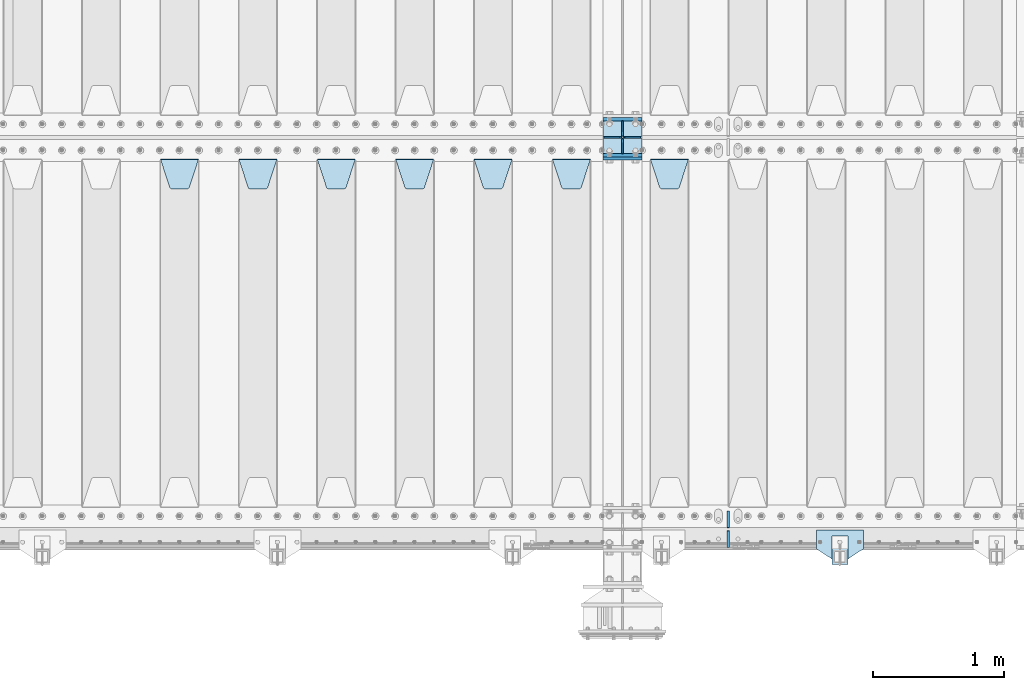
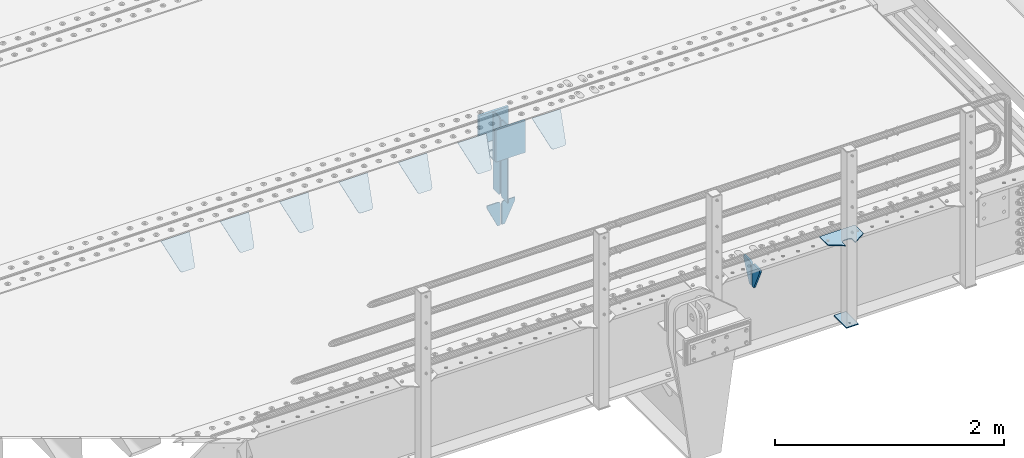
# One storey, part 200 of 240: 22 plates.
"""IFC2X3 building model written with IfcOpenShell, lengths in millimetres."""

from ifc_helpers import new_model, si_unit, frame, origin_with_axes, place, context, subcontext, project, spatial, faceted_brep, material, type_object, element, save


model = new_model("IFC2X3")

# Units and contexts
model_context = context("Model", 3, precision=1e-05, world=origin_with_axes())
body_context = subcontext(model_context, "Body", "Model", "MODEL_VIEW")
ifc_project = project(units=[si_unit("LENGTHUNIT", "METRE", prefix="MILLI"), si_unit("AREAUNIT", "SQUARE_METRE"), si_unit("VOLUMEUNIT", "CUBIC_METRE"), si_unit("MASSUNIT", "GRAM", prefix="KILO"), si_unit("TIMEUNIT", "SECOND"), si_unit("PLANEANGLEUNIT", "RADIAN"), si_unit("SOLIDANGLEUNIT", "STERADIAN"), si_unit("THERMODYNAMICTEMPERATUREUNIT", "DEGREE_CELSIUS"), si_unit("LUMINOUSINTENSITYUNIT", "LUMEN")], contexts=[model_context])

# Site, building, storey
site_placement = place(None, origin_with_axes())
site = spatial("IfcSite", under=ifc_project, at=site_placement, CompositionType="ELEMENT")
building_placement = place(site_placement, origin_with_axes())
building = spatial("IfcBuilding", under=site, at=building_placement, Name="Standard", CompositionType="ELEMENT")
storey_placement = place(building_placement, origin_with_axes())
storey = spatial("IfcBuildingStorey", under=building, at=storey_placement, Name="Undefined", CompositionType="ELEMENT", Elevation=0.0)

# Plates
ifc_material_1 = material(Name="STEEL/S355N")
plate_type_1 = type_object("IfcPlateType", PredefinedType="NOTDEFINED")
for number, where, z_axis, x_axis in (
    (1, (52690.0, 27137.5, -340.0), (0.0, 0.0, 1.0), (1.0, 0.0, 0.0)),
    (2, (52690.0, 26862.5, -340.0), (0.0, 0.0, 1.0), (1.0, 0.0, 0.0)),
):
    element("IfcPlate", number, at=place(storey_placement, frame(where, z_axis=z_axis, x_axis=x_axis)), inside=storey, type_object=plate_type_1, material=ifc_material_1, context=body_context, shape_type="Brep", body=[
        faceted_brep([(0.0, -12.5, 0.0), (0.0, -12.5, 310.0), (0.0, 12.5, 310.0), (0.0, 12.5, 0.0), (300.0, -12.5, 310.0), (300.0, 12.5, 310.0), (300.0, -12.5, 0.0), (300.0, 12.5, 0.0)], [[[0, 1, 2, 3]], [[1, 4, 5, 2]], [[4, 6, 7, 5]], [[6, 0, 3, 7]], [[5, 7, 3, 2]], [[6, 4, 1, 0]]]),
    ])
plate_1_placement = place(storey_placement, frame((52690.0, 26837.5, -340.000000000044), z_axis=(0.0, 0.0, 1.0), x_axis=(1.0, 0.0, 0.0)))
element("IfcPlate", 3, at=plate_1_placement, inside=storey, type_object=plate_type_1, material=ifc_material_1, context=body_context, shape_type="Brep", body=[
    faceted_brep([(0.0, -12.5, 0.0), (9.31322574615479e-10, -12.5, 340.0), (9.31322574615479e-10, 12.5, 340.0), (0.0, 12.5, 0.0), (300.0, -12.5, 340.0), (300.0, 12.5, 340.0), (300.0, -12.5, 0.0), (300.0, 12.5, 0.0)], [[[0, 1, 2, 3]], [[1, 4, 5, 2]], [[4, 6, 7, 5]], [[6, 0, 3, 7]], [[5, 7, 3, 2]], [[6, 4, 1, 0]]]),
])
plate_type_2 = type_object("IfcPlateType", PredefinedType="NOTDEFINED")
for number, where, z_axis, x_axis in (
    (4, (52690.0, 26992.0, -343.0), (0.0, -1.0, 0.0), (1.0, 0.0, 0.0)),
    (5, (52690.0, 27008.0, -343.0), (0.0, 1.0, 0.0), (1.0, 0.0, 0.0)),
):
    element("IfcPlate", number, at=place(storey_placement, frame(where, z_axis=z_axis, x_axis=x_axis)), inside=storey, type_object=plate_type_2, material=ifc_material_1, context=body_context, shape_type="Brep", body=[
        faceted_brep([(0.0, -7.0, 0.0), (0.0, -7.0, 117.0), (0.0, 7.0, 117.0), (0.0, 7.0, 0.0), (300.0, -7.0, 117.0), (300.0, 7.0, 117.0), (300.0, -7.0, 0.0), (300.0, 7.0, 0.0)], [[[0, 1, 2, 3]], [[1, 4, 5, 2]], [[4, 6, 7, 5]], [[6, 0, 3, 7]], [[5, 7, 3, 2]], [[6, 4, 1, 0]]]),
    ])
plate_type_3 = type_object("IfcPlateType", PredefinedType="NOTDEFINED")
for number, where, z_axis, x_axis in (
    (6, (52840.0, 27008.0, -30.0), (0.0, 0.0, -1.0), (0.0, 1.0, 0.0)),
    (7, (52840.0, 26992.0, -30.0), (0.0, 0.0, -1.0), (0.0, -1.0, 0.0)),
):
    element("IfcPlate", number, at=place(storey_placement, frame(where, z_axis=z_axis, x_axis=x_axis)), inside=storey, type_object=plate_type_3, material=ifc_material_1, context=body_context, shape_type="Brep", body=[
        faceted_brep([(0.0, -5.0, 30.0), (0.0, -5.0, 306.0), (0.0, 5.0, 306.0), (0.0, 5.0, 30.0), (117.0, -5.0, 306.0), (117.0, 5.0, 306.0), (117.0, -5.0, 0.0), (117.0, 5.0, 0.0), (30.0, -5.0, 0.0), (30.0, 5.0, 0.0), (24.7905546699913, -5.0, 0.455767409633758), (24.7905546699913, 5.0, 0.455767409633758), (19.7393957002278, -5.0, 1.80922137642275), (19.7393957002278, 5.0, 1.80922137642275), (15.0, -5.0, 4.01923788646684), (15.0, 5.0, 4.01923788646684), (10.7163717094008, -5.0, 7.01866670643066), (10.7163717094008, 5.0, 7.01866670643066), (7.01866670643358, -5.0, 10.7163717094038), (7.01866670643358, 5.0, 10.7163717094038), (4.01923788646673, -5.0, 15.0), (4.01923788646673, 5.0, 15.0), (1.80922137642483, -5.0, 19.7393957002299), (1.80922137642483, 5.0, 19.7393957002299), (0.455767409635882, -5.0, 24.7905546699921), (0.455767409635882, 5.0, 24.7905546699921)], [[[0, 1, 2, 3]], [[1, 4, 5, 2]], [[4, 6, 7, 5]], [[6, 8, 9, 7]], [[8, 10, 11, 9]], [[10, 12, 13, 11]], [[12, 14, 15, 13]], [[14, 16, 17, 15]], [[16, 18, 19, 17]], [[18, 20, 21, 19]], [[20, 22, 23, 21]], [[22, 24, 25, 23]], [[24, 0, 3, 25]], [[5, 7, 9, 11, 13, 15, 17, 19, 21, 23, 25, 3, 2]], [[24, 22, 20, 18, 16, 14, 12, 10, 8, 6, 4, 1, 0]]]),
    ])
for number, where, z_axis, x_axis in (
    (8, (52840.0, 26992.0, -350.0), (0.0, 0.0, -1.0), (0.0, -1.0, 0.0)),
    (9, (52840.0, 27008.0, -350.0), (0.0, 0.0, -1.0), (0.0, 1.0, 0.0)),
):
    element("IfcPlate", number, at=place(storey_placement, frame(where, z_axis=z_axis, x_axis=x_axis)), inside=storey, type_object=plate_type_3, material=ifc_material_1, context=body_context, shape_type="Brep", body=[
        faceted_brep([(0.0, -5.0, 0.0), (0.0, -5.0, 480.0), (0.0, 5.0, 480.0), (0.0, 5.0, 0.0), (0.455767409635882, -5.0, 485.209445330008), (0.455767409635882, 5.0, 485.209445330008), (1.80922137642483, -5.0, 490.26060429977), (1.80922137642483, 5.0, 490.26060429977), (4.01923788646673, -5.0, 495.0), (4.01923788646673, 5.0, 495.0), (7.01866670643358, -5.0, 499.283628290596), (7.01866670643358, 5.0, 499.283628290596), (10.7163717094008, -5.0, 502.981333293569), (10.7163717094008, 5.0, 502.981333293569), (15.0, -5.0, 505.980762113533), (15.0, 5.0, 505.980762113533), (19.7393957002278, -5.0, 508.190778623577), (19.7393957002278, 5.0, 508.190778623577), (24.7905546699913, -5.0, 509.544232590366), (24.7905546699913, 5.0, 509.544232590366), (30.0, -5.0, 510.0), (30.0, 5.0, 510.0), (117.0, -5.0, 510.0), (117.0, 5.0, 510.0), (117.0, -5.0, 0.0), (117.0, 5.0, 0.0)], [[[0, 1, 2, 3]], [[1, 4, 5, 2]], [[4, 6, 7, 5]], [[6, 8, 9, 7]], [[8, 10, 11, 9]], [[10, 12, 13, 11]], [[12, 14, 15, 13]], [[14, 16, 17, 15]], [[16, 18, 19, 17]], [[18, 20, 21, 19]], [[20, 22, 23, 21]], [[22, 24, 25, 23]], [[24, 0, 3, 25]], [[5, 7, 9, 11, 13, 15, 17, 19, 21, 23, 25, 3, 2]], [[24, 22, 20, 18, 16, 14, 12, 10, 8, 6, 4, 1, 0]]]),
    ])
plate_type_4 = type_object("IfcPlateType", PredefinedType="NOTDEFINED")
for number, where, z_axis, x_axis in (
    (10, (52833.4999999989, 27000.0000000345, -915.000018222274), (0.0, 0.0, -1.0), (-1.0, 0.0, 0.0)),
    (11, (52846.4999999991, 27000.0000000345, -915.000018222273), (0.0, 0.0, -1.0), (1.0, 0.0, 0.0)),
):
    element("IfcPlate", number, at=place(storey_placement, frame(where, z_axis=z_axis, x_axis=x_axis)), inside=storey, type_object=plate_type_4, material=ifc_material_1, context=body_context, shape_type="Brep", body=[
        faceted_brep([(0.0, -5.0, 27.0), (0.0, -5.0, 250.0), (0.0, 5.0, 250.0), (0.0, 5.0, 27.0), (30.0, -5.0, 250.0), (30.0, 5.0, 250.0), (135.0, -5.0, 30.0), (135.0, 5.0, 30.0), (135.0, -5.0, 0.0), (135.0, 5.0, 0.0), (27.0, -5.0, 0.0), (27.0, 5.0, 0.0), (22.311499202995, -5.0, 0.410190668670339), (22.311499202995, 5.0, 0.410190668670339), (17.7654561302043, -5.0, 1.62829923878053), (17.7654561302043, 5.0, 1.62829923878053), (13.5, -5.0, 3.6173140978201), (13.5, 5.0, 3.6173140978201), (9.64473453846585, -5.0, 6.31680003578754), (9.64473453846585, 5.0, 6.31680003578754), (6.31680003579095, -5.0, 9.64473453846347), (6.31680003579095, 5.0, 9.64473453846347), (3.61731409782078, -5.0, 13.5), (3.61731409782078, 5.0, 13.5), (1.62829923877871, -5.0, 17.765456130207), (1.62829923877871, 5.0, 17.765456130207), (0.410190668670111, -5.0, 22.3114992029929), (0.410190668670111, 5.0, 22.3114992029929)], [[[0, 1, 2, 3]], [[1, 4, 5, 2]], [[4, 6, 7, 5]], [[6, 8, 9, 7]], [[8, 10, 11, 9]], [[10, 12, 13, 11]], [[12, 14, 15, 13]], [[14, 16, 17, 15]], [[16, 18, 19, 17]], [[18, 20, 21, 19]], [[20, 22, 23, 21]], [[22, 24, 25, 23]], [[24, 26, 27, 25]], [[26, 0, 3, 27]], [[5, 7, 9, 11, 13, 15, 17, 19, 21, 23, 25, 27, 3, 2]], [[26, 24, 22, 20, 18, 16, 14, 12, 10, 8, 6, 4, 1, 0]]]),
    ])
plate_type_5 = type_object("IfcPlateType", PredefinedType="NOTDEFINED")
plate_2_placement = place(storey_placement, frame((53055.0, 26831.767766956, -1.76776695296758), z_axis=(0.0, -0.707106781186547, -0.707106781186548), x_axis=(1.0, 0.0, 0.0)))
element("IfcPlate", 12, at=plate_2_placement, inside=storey, type_object=plate_type_5, material=ifc_material_1, context=body_context, shape_type="Brep", body=[
    faceted_brep([(0.0, -2.5, 0.0), (69.345504679477, -2.50000000000364, 300.171731424827), (69.345504679477, 2.49999999999636, 300.171731424827), (0.0, 2.5, 0.0), (70.927406119954, -2.50000000000364, 304.897442415397), (70.927406119954, 2.49999999999636, 304.897442415397), (73.3818627772271, -2.50000000000728, 309.234538108525), (73.3818627772271, 2.49999999999636, 309.234538108529), (76.6187032999587, -2.50000000000728, 313.023683126099), (76.6187032999587, 2.49999999999636, 313.023683126103), (80.5190132705029, -2.50000000000364, 316.125672595368), (80.5190132705029, 2.49999999999636, 316.125672595368), (84.9395038596849, -2.50000000000364, 318.426546230472), (84.9395038596849, 2.49999999999636, 318.426546230472), (89.7177759439219, -2.5, 319.841774983277), (89.7177759439219, 2.49999999999636, 319.841774983273), (94.6782862926484, -2.50000000000364, 320.319366455074), (94.6782862926484, 2.49999999999636, 320.319366455074), (195.321713707352, -2.50000000000364, 320.319366455074), (195.321713707352, 2.49999999999636, 320.319366455074), (200.282224056078, -2.50000000000364, 319.841774983273), (200.282224056078, 2.49999999999636, 319.841774983273), (205.060496140315, -2.50000000000364, 318.426546230472), (205.060496140315, 2.49999999999636, 318.426546230472), (209.480986729497, -2.50000000000364, 316.125672595368), (209.480986729497, 2.49999999999636, 316.125672595368), (213.381296700041, -2.50000000000728, 313.023683126099), (213.381296700041, 2.49999999999272, 313.023683126099), (216.618137222766, -2.50000000000364, 309.234538108522), (216.618137222766, 2.49999999999636, 309.234538108522), (219.072593880039, -2.50000000000364, 304.897442415397), (219.072593880039, 2.49999999999636, 304.897442415397), (220.654495320523, -2.50000000000364, 300.171731424827), (220.654495320523, 2.49999999999636, 300.171731424827), (290.0, -2.50000000000364, -3.63797880709171e-12), (290.0, 2.49999999999636, -3.63797880709171e-12)], [[[0, 1, 2, 3]], [[1, 4, 5, 2]], [[4, 6, 7, 5]], [[6, 8, 9, 7]], [[8, 10, 11, 9]], [[10, 12, 13, 11]], [[12, 14, 15, 13]], [[14, 16, 17, 15]], [[16, 18, 19, 17]], [[18, 20, 21, 19]], [[20, 22, 23, 21]], [[22, 24, 25, 23]], [[24, 26, 27, 25]], [[26, 28, 29, 27]], [[28, 30, 31, 29]], [[30, 32, 33, 31]], [[32, 34, 35, 33]], [[34, 0, 3, 35]], [[5, 7, 9, 11, 13, 15, 17, 19, 21, 23, 25, 27, 29, 31, 33, 35, 3, 2]], [[34, 32, 30, 28, 26, 24, 22, 20, 18, 16, 14, 12, 10, 8, 6, 4, 1, 0]]]),
])
plate_3_placement = place(storey_placement, frame((52305.0, 26831.767766956, -1.76776695296758), z_axis=(0.0, -0.707106781186547, -0.707106781186548), x_axis=(1.0, 0.0, 0.0)))
element("IfcPlate", 13, at=plate_3_placement, inside=storey, type_object=plate_type_5, material=ifc_material_1, context=body_context, shape_type="Brep", body=[
    faceted_brep([(0.0, -2.5, 0.0), (69.345504679477, -2.50000000000364, 300.171731424827), (69.345504679477, 2.49999999999636, 300.171731424827), (0.0, 2.5, 0.0), (70.927406119954, -2.50000000000364, 304.897442415397), (70.927406119954, 2.49999999999636, 304.897442415397), (73.3818627772271, -2.50000000000728, 309.234538108525), (73.3818627772271, 2.49999999999636, 309.234538108529), (76.6187032999587, -2.50000000000728, 313.023683126099), (76.6187032999587, 2.49999999999636, 313.023683126103), (80.5190132705029, -2.50000000000364, 316.125672595368), (80.5190132705029, 2.49999999999636, 316.125672595368), (84.9395038596849, -2.50000000000364, 318.426546230472), (84.9395038596849, 2.49999999999636, 318.426546230472), (89.7177759439219, -2.5, 319.841774983277), (89.7177759439219, 2.49999999999636, 319.841774983273), (94.6782862926484, -2.50000000000364, 320.319366455074), (94.6782862926484, 2.49999999999636, 320.319366455074), (195.321713707352, -2.50000000000364, 320.319366455074), (195.321713707352, 2.49999999999636, 320.319366455074), (200.282224056078, -2.50000000000364, 319.841774983273), (200.282224056078, 2.49999999999636, 319.841774983273), (205.060496140315, -2.50000000000364, 318.426546230472), (205.060496140315, 2.49999999999636, 318.426546230472), (209.480986729497, -2.50000000000364, 316.125672595368), (209.480986729497, 2.49999999999636, 316.125672595368), (213.381296700041, -2.50000000000728, 313.023683126099), (213.381296700041, 2.49999999999272, 313.023683126099), (216.618137222766, -2.50000000000364, 309.234538108522), (216.618137222766, 2.49999999999636, 309.234538108522), (219.072593880039, -2.50000000000364, 304.897442415397), (219.072593880039, 2.49999999999636, 304.897442415397), (220.654495320523, -2.50000000000364, 300.171731424827), (220.654495320523, 2.49999999999636, 300.171731424827), (290.0, -2.50000000000364, -3.63797880709171e-12), (290.0, 2.49999999999636, -3.63797880709171e-12)], [[[0, 1, 2, 3]], [[1, 4, 5, 2]], [[4, 6, 7, 5]], [[6, 8, 9, 7]], [[8, 10, 11, 9]], [[10, 12, 13, 11]], [[12, 14, 15, 13]], [[14, 16, 17, 15]], [[16, 18, 19, 17]], [[18, 20, 21, 19]], [[20, 22, 23, 21]], [[22, 24, 25, 23]], [[24, 26, 27, 25]], [[26, 28, 29, 27]], [[28, 30, 31, 29]], [[30, 32, 33, 31]], [[32, 34, 35, 33]], [[34, 0, 3, 35]], [[5, 7, 9, 11, 13, 15, 17, 19, 21, 23, 25, 27, 29, 31, 33, 35, 3, 2]], [[34, 32, 30, 28, 26, 24, 22, 20, 18, 16, 14, 12, 10, 8, 6, 4, 1, 0]]]),
])
plate_4_placement = place(storey_placement, frame((51705.0, 26831.767766956, -1.76776695296758), z_axis=(0.0, -0.707106781186547, -0.707106781186548), x_axis=(1.0, 0.0, 0.0)))
element("IfcPlate", 14, at=plate_4_placement, inside=storey, type_object=plate_type_5, material=ifc_material_1, context=body_context, shape_type="Brep", body=[
    faceted_brep([(0.0, -2.5, 0.0), (69.345504679477, -2.50000000000364, 300.171731424827), (69.345504679477, 2.49999999999636, 300.171731424827), (0.0, 2.5, 0.0), (70.927406119954, -2.50000000000364, 304.897442415397), (70.927406119954, 2.49999999999636, 304.897442415397), (73.3818627772271, -2.50000000000728, 309.234538108525), (73.3818627772271, 2.49999999999636, 309.234538108529), (76.6187032999587, -2.50000000000728, 313.023683126099), (76.6187032999587, 2.49999999999636, 313.023683126103), (80.5190132705029, -2.50000000000364, 316.125672595368), (80.5190132705029, 2.49999999999636, 316.125672595368), (84.9395038596849, -2.50000000000364, 318.426546230472), (84.9395038596849, 2.49999999999636, 318.426546230472), (89.7177759439219, -2.5, 319.841774983277), (89.7177759439219, 2.49999999999636, 319.841774983273), (94.6782862926484, -2.50000000000364, 320.319366455074), (94.6782862926484, 2.49999999999636, 320.319366455074), (195.321713707352, -2.50000000000364, 320.319366455074), (195.321713707352, 2.49999999999636, 320.319366455074), (200.282224056078, -2.50000000000364, 319.841774983273), (200.282224056078, 2.49999999999636, 319.841774983273), (205.060496140315, -2.50000000000364, 318.426546230472), (205.060496140315, 2.49999999999636, 318.426546230472), (209.480986729497, -2.50000000000364, 316.125672595368), (209.480986729497, 2.49999999999636, 316.125672595368), (213.381296700041, -2.50000000000728, 313.023683126099), (213.381296700041, 2.49999999999272, 313.023683126099), (216.618137222766, -2.50000000000364, 309.234538108522), (216.618137222766, 2.49999999999636, 309.234538108522), (219.072593880039, -2.50000000000364, 304.897442415397), (219.072593880039, 2.49999999999636, 304.897442415397), (220.654495320523, -2.50000000000364, 300.171731424827), (220.654495320523, 2.49999999999636, 300.171731424827), (290.0, -2.50000000000364, -3.63797880709171e-12), (290.0, 2.49999999999636, -3.63797880709171e-12)], [[[0, 1, 2, 3]], [[1, 4, 5, 2]], [[4, 6, 7, 5]], [[6, 8, 9, 7]], [[8, 10, 11, 9]], [[10, 12, 13, 11]], [[12, 14, 15, 13]], [[14, 16, 17, 15]], [[16, 18, 19, 17]], [[18, 20, 21, 19]], [[20, 22, 23, 21]], [[22, 24, 25, 23]], [[24, 26, 27, 25]], [[26, 28, 29, 27]], [[28, 30, 31, 29]], [[30, 32, 33, 31]], [[32, 34, 35, 33]], [[34, 0, 3, 35]], [[5, 7, 9, 11, 13, 15, 17, 19, 21, 23, 25, 27, 29, 31, 33, 35, 3, 2]], [[34, 32, 30, 28, 26, 24, 22, 20, 18, 16, 14, 12, 10, 8, 6, 4, 1, 0]]]),
])
plate_5_placement = place(storey_placement, frame((51105.0, 26831.767766956, -1.76776695296758), z_axis=(0.0, -0.707106781186547, -0.707106781186548), x_axis=(1.0, 0.0, 0.0)))
element("IfcPlate", 15, at=plate_5_placement, inside=storey, type_object=plate_type_5, material=ifc_material_1, context=body_context, shape_type="Brep", body=[
    faceted_brep([(0.0, -2.5, 0.0), (69.345504679477, -2.50000000000364, 300.171731424827), (69.345504679477, 2.49999999999636, 300.171731424827), (0.0, 2.5, 0.0), (70.927406119954, -2.50000000000364, 304.897442415397), (70.927406119954, 2.49999999999636, 304.897442415397), (73.3818627772271, -2.50000000000728, 309.234538108525), (73.3818627772271, 2.49999999999636, 309.234538108529), (76.6187032999587, -2.50000000000728, 313.023683126099), (76.6187032999587, 2.49999999999636, 313.023683126103), (80.5190132705029, -2.50000000000364, 316.125672595368), (80.5190132705029, 2.49999999999636, 316.125672595368), (84.9395038596849, -2.50000000000364, 318.426546230472), (84.9395038596849, 2.49999999999636, 318.426546230472), (89.7177759439219, -2.5, 319.841774983277), (89.7177759439219, 2.49999999999636, 319.841774983273), (94.6782862926484, -2.50000000000364, 320.319366455074), (94.6782862926484, 2.49999999999636, 320.319366455074), (195.321713707352, -2.50000000000364, 320.319366455074), (195.321713707352, 2.49999999999636, 320.319366455074), (200.282224056078, -2.50000000000364, 319.841774983273), (200.282224056078, 2.49999999999636, 319.841774983273), (205.060496140315, -2.50000000000364, 318.426546230472), (205.060496140315, 2.49999999999636, 318.426546230472), (209.480986729497, -2.50000000000364, 316.125672595368), (209.480986729497, 2.49999999999636, 316.125672595368), (213.381296700041, -2.50000000000728, 313.023683126099), (213.381296700041, 2.49999999999272, 313.023683126099), (216.618137222766, -2.50000000000364, 309.234538108522), (216.618137222766, 2.49999999999636, 309.234538108522), (219.072593880039, -2.50000000000364, 304.897442415397), (219.072593880039, 2.49999999999636, 304.897442415397), (220.654495320523, -2.50000000000364, 300.171731424827), (220.654495320523, 2.49999999999636, 300.171731424827), (290.0, -2.50000000000364, -3.63797880709171e-12), (290.0, 2.49999999999636, -3.63797880709171e-12)], [[[0, 1, 2, 3]], [[1, 4, 5, 2]], [[4, 6, 7, 5]], [[6, 8, 9, 7]], [[8, 10, 11, 9]], [[10, 12, 13, 11]], [[12, 14, 15, 13]], [[14, 16, 17, 15]], [[16, 18, 19, 17]], [[18, 20, 21, 19]], [[20, 22, 23, 21]], [[22, 24, 25, 23]], [[24, 26, 27, 25]], [[26, 28, 29, 27]], [[28, 30, 31, 29]], [[30, 32, 33, 31]], [[32, 34, 35, 33]], [[34, 0, 3, 35]], [[5, 7, 9, 11, 13, 15, 17, 19, 21, 23, 25, 27, 29, 31, 33, 35, 3, 2]], [[34, 32, 30, 28, 26, 24, 22, 20, 18, 16, 14, 12, 10, 8, 6, 4, 1, 0]]]),
])
plate_6_placement = place(storey_placement, frame((50505.0, 26831.767766956, -1.76776695296758), z_axis=(0.0, -0.707106781186547, -0.707106781186548), x_axis=(1.0, 0.0, 0.0)))
element("IfcPlate", 16, at=plate_6_placement, inside=storey, type_object=plate_type_5, material=ifc_material_1, context=body_context, shape_type="Brep", body=[
    faceted_brep([(0.0, -2.5, 0.0), (69.345504679477, -2.50000000000364, 300.171731424827), (69.345504679477, 2.49999999999636, 300.171731424827), (0.0, 2.5, 0.0), (70.927406119954, -2.50000000000364, 304.897442415397), (70.927406119954, 2.49999999999636, 304.897442415397), (73.3818627772271, -2.50000000000728, 309.234538108525), (73.3818627772271, 2.49999999999636, 309.234538108529), (76.6187032999587, -2.50000000000728, 313.023683126099), (76.6187032999587, 2.49999999999636, 313.023683126103), (80.5190132705029, -2.50000000000364, 316.125672595368), (80.5190132705029, 2.49999999999636, 316.125672595368), (84.9395038596849, -2.50000000000364, 318.426546230472), (84.9395038596849, 2.49999999999636, 318.426546230472), (89.7177759439219, -2.5, 319.841774983277), (89.7177759439219, 2.49999999999636, 319.841774983273), (94.6782862926484, -2.50000000000364, 320.319366455074), (94.6782862926484, 2.49999999999636, 320.319366455074), (195.321713707352, -2.50000000000364, 320.319366455074), (195.321713707352, 2.49999999999636, 320.319366455074), (200.282224056078, -2.50000000000364, 319.841774983273), (200.282224056078, 2.49999999999636, 319.841774983273), (205.060496140315, -2.50000000000364, 318.426546230472), (205.060496140315, 2.49999999999636, 318.426546230472), (209.480986729497, -2.50000000000364, 316.125672595368), (209.480986729497, 2.49999999999636, 316.125672595368), (213.381296700041, -2.50000000000728, 313.023683126099), (213.381296700041, 2.49999999999272, 313.023683126099), (216.618137222766, -2.50000000000364, 309.234538108522), (216.618137222766, 2.49999999999636, 309.234538108522), (219.072593880039, -2.50000000000364, 304.897442415397), (219.072593880039, 2.49999999999636, 304.897442415397), (220.654495320523, -2.50000000000364, 300.171731424827), (220.654495320523, 2.49999999999636, 300.171731424827), (290.0, -2.50000000000364, -3.63797880709171e-12), (290.0, 2.49999999999636, -3.63797880709171e-12)], [[[0, 1, 2, 3]], [[1, 4, 5, 2]], [[4, 6, 7, 5]], [[6, 8, 9, 7]], [[8, 10, 11, 9]], [[10, 12, 13, 11]], [[12, 14, 15, 13]], [[14, 16, 17, 15]], [[16, 18, 19, 17]], [[18, 20, 21, 19]], [[20, 22, 23, 21]], [[22, 24, 25, 23]], [[24, 26, 27, 25]], [[26, 28, 29, 27]], [[28, 30, 31, 29]], [[30, 32, 33, 31]], [[32, 34, 35, 33]], [[34, 0, 3, 35]], [[5, 7, 9, 11, 13, 15, 17, 19, 21, 23, 25, 27, 29, 31, 33, 35, 3, 2]], [[34, 32, 30, 28, 26, 24, 22, 20, 18, 16, 14, 12, 10, 8, 6, 4, 1, 0]]]),
])
plate_7_placement = place(storey_placement, frame((49905.0, 26831.767766956, -1.76776695296758), z_axis=(0.0, -0.707106781186547, -0.707106781186548), x_axis=(1.0, 0.0, 0.0)))
element("IfcPlate", 17, at=plate_7_placement, inside=storey, type_object=plate_type_5, material=ifc_material_1, context=body_context, shape_type="Brep", body=[
    faceted_brep([(0.0, -2.5, 0.0), (69.345504679477, -2.50000000000364, 300.171731424827), (69.345504679477, 2.49999999999636, 300.171731424827), (0.0, 2.5, 0.0), (70.927406119954, -2.50000000000364, 304.897442415397), (70.927406119954, 2.49999999999636, 304.897442415397), (73.3818627772271, -2.50000000000728, 309.234538108525), (73.3818627772271, 2.49999999999636, 309.234538108529), (76.6187032999587, -2.50000000000728, 313.023683126099), (76.6187032999587, 2.49999999999636, 313.023683126103), (80.5190132705029, -2.50000000000364, 316.125672595368), (80.5190132705029, 2.49999999999636, 316.125672595368), (84.9395038596849, -2.50000000000364, 318.426546230472), (84.9395038596849, 2.49999999999636, 318.426546230472), (89.7177759439219, -2.5, 319.841774983277), (89.7177759439219, 2.49999999999636, 319.841774983273), (94.6782862926484, -2.50000000000364, 320.319366455074), (94.6782862926484, 2.49999999999636, 320.319366455074), (195.321713707352, -2.50000000000364, 320.319366455074), (195.321713707352, 2.49999999999636, 320.319366455074), (200.282224056078, -2.50000000000364, 319.841774983273), (200.282224056078, 2.49999999999636, 319.841774983273), (205.060496140315, -2.50000000000364, 318.426546230472), (205.060496140315, 2.49999999999636, 318.426546230472), (209.480986729497, -2.50000000000364, 316.125672595368), (209.480986729497, 2.49999999999636, 316.125672595368), (213.381296700041, -2.50000000000728, 313.023683126099), (213.381296700041, 2.49999999999272, 313.023683126099), (216.618137222766, -2.50000000000364, 309.234538108522), (216.618137222766, 2.49999999999636, 309.234538108522), (219.072593880039, -2.50000000000364, 304.897442415397), (219.072593880039, 2.49999999999636, 304.897442415397), (220.654495320523, -2.50000000000364, 300.171731424827), (220.654495320523, 2.49999999999636, 300.171731424827), (290.0, -2.50000000000364, -3.63797880709171e-12), (290.0, 2.49999999999636, -3.63797880709171e-12)], [[[0, 1, 2, 3]], [[1, 4, 5, 2]], [[4, 6, 7, 5]], [[6, 8, 9, 7]], [[8, 10, 11, 9]], [[10, 12, 13, 11]], [[12, 14, 15, 13]], [[14, 16, 17, 15]], [[16, 18, 19, 17]], [[18, 20, 21, 19]], [[20, 22, 23, 21]], [[22, 24, 25, 23]], [[24, 26, 27, 25]], [[26, 28, 29, 27]], [[28, 30, 31, 29]], [[30, 32, 33, 31]], [[32, 34, 35, 33]], [[34, 0, 3, 35]], [[5, 7, 9, 11, 13, 15, 17, 19, 21, 23, 25, 27, 29, 31, 33, 35, 3, 2]], [[34, 32, 30, 28, 26, 24, 22, 20, 18, 16, 14, 12, 10, 8, 6, 4, 1, 0]]]),
])
plate_8_placement = place(storey_placement, frame((49305.0, 26831.767766956, -1.76776695296758), z_axis=(0.0, -0.707106781186547, -0.707106781186548), x_axis=(1.0, 0.0, 0.0)))
element("IfcPlate", 18, at=plate_8_placement, inside=storey, type_object=plate_type_5, material=ifc_material_1, context=body_context, shape_type="Brep", body=[
    faceted_brep([(0.0, -2.5, 0.0), (69.345504679477, -2.50000000000364, 300.171731424827), (69.345504679477, 2.49999999999636, 300.171731424827), (0.0, 2.5, 0.0), (70.927406119954, -2.50000000000364, 304.897442415397), (70.927406119954, 2.49999999999636, 304.897442415397), (73.3818627772271, -2.50000000000728, 309.234538108525), (73.3818627772271, 2.49999999999636, 309.234538108529), (76.6187032999587, -2.50000000000728, 313.023683126099), (76.6187032999587, 2.49999999999636, 313.023683126103), (80.5190132705029, -2.50000000000364, 316.125672595368), (80.5190132705029, 2.49999999999636, 316.125672595368), (84.9395038596849, -2.50000000000364, 318.426546230472), (84.9395038596849, 2.49999999999636, 318.426546230472), (89.7177759439219, -2.5, 319.841774983277), (89.7177759439219, 2.49999999999636, 319.841774983273), (94.6782862926484, -2.50000000000364, 320.319366455074), (94.6782862926484, 2.49999999999636, 320.319366455074), (195.321713707352, -2.50000000000364, 320.319366455074), (195.321713707352, 2.49999999999636, 320.319366455074), (200.282224056078, -2.50000000000364, 319.841774983273), (200.282224056078, 2.49999999999636, 319.841774983273), (205.060496140315, -2.50000000000364, 318.426546230472), (205.060496140315, 2.49999999999636, 318.426546230472), (209.480986729497, -2.50000000000364, 316.125672595368), (209.480986729497, 2.49999999999636, 316.125672595368), (213.381296700041, -2.50000000000728, 313.023683126099), (213.381296700041, 2.49999999999272, 313.023683126099), (216.618137222766, -2.50000000000364, 309.234538108522), (216.618137222766, 2.49999999999636, 309.234538108522), (219.072593880039, -2.50000000000364, 304.897442415397), (219.072593880039, 2.49999999999636, 304.897442415397), (220.654495320523, -2.50000000000364, 300.171731424827), (220.654495320523, 2.49999999999636, 300.171731424827), (290.0, -2.50000000000364, -3.63797880709171e-12), (290.0, 2.49999999999636, -3.63797880709171e-12)], [[[0, 1, 2, 3]], [[1, 4, 5, 2]], [[4, 6, 7, 5]], [[6, 8, 9, 7]], [[8, 10, 11, 9]], [[10, 12, 13, 11]], [[12, 14, 15, 13]], [[14, 16, 17, 15]], [[16, 18, 19, 17]], [[18, 20, 21, 19]], [[20, 22, 23, 21]], [[22, 24, 25, 23]], [[24, 26, 27, 25]], [[26, 28, 29, 27]], [[28, 30, 31, 29]], [[30, 32, 33, 31]], [[32, 34, 35, 33]], [[34, 0, 3, 35]], [[5, 7, 9, 11, 13, 15, 17, 19, 21, 23, 25, 27, 29, 31, 33, 35, 3, 2]], [[34, 32, 30, 28, 26, 24, 22, 20, 18, 16, 14, 12, 10, 8, 6, 4, 1, 0]]]),
])
plate_type_6 = type_object("IfcPlateType", PredefinedType="NOTDEFINED")
for number, where, z_axis, x_axis in (
    (19, (53650.0, 23860.0, -30.0), (0.0, 0.0, -1.0), (0.0, 1.0, 0.0)),
    (20, (53650.0, 24140.0, -30.0), (0.0, 0.0, -1.0), (0.0, -1.0, 0.0)),
):
    element("IfcPlate", number, at=place(storey_placement, frame(where, z_axis=z_axis, x_axis=x_axis)), inside=storey, type_object=plate_type_6, material=ifc_material_1, context=body_context, shape_type="Brep", body=[
        faceted_brep([(0.0, -10.0, 0.0), (0.0, -10.0, 30.0), (0.0, 10.0, 30.0), (0.0, 10.0, 0.0), (102.0, -10.0, 250.0), (102.0, 10.0, 250.0), (132.0, -10.0, 250.0), (132.0, 10.0, 250.0), (132.0, -10.0, 30.0), (132.0, 10.0, 30.0), (131.544232590368, -10.0, 24.790554669992), (131.544232590368, 10.0, 24.790554669992), (130.190778623579, -10.0, 19.7393957002299), (130.190778623579, 10.0, 19.7393957002299), (127.980762113533, -10.0, 15.0), (127.980762113533, 10.0, 15.0), (124.98133329357, -10.0, 10.7163717094038), (124.98133329357, 10.0, 10.7163717094038), (121.283628290596, -10.0, 7.01866670643062), (121.283628290596, 10.0, 7.01866670643062), (117.0, -10.0, 4.01923788646684), (117.0, 10.0, 4.01923788646684), (112.260604299769, -10.0, 1.80922137642278), (112.260604299769, 10.0, 1.80922137642278), (107.209445330009, -10.0, 0.455767409633722), (107.209445330009, 10.0, 0.455767409633722), (102.0, -10.0, 0.0), (102.0, 10.0, 0.0)], [[[0, 1, 2, 3]], [[1, 4, 5, 2]], [[4, 6, 7, 5]], [[6, 8, 9, 7]], [[8, 10, 11, 9]], [[10, 12, 13, 11]], [[12, 14, 15, 13]], [[14, 16, 17, 15]], [[16, 18, 19, 17]], [[18, 20, 21, 19]], [[20, 22, 23, 21]], [[22, 24, 25, 23]], [[24, 26, 27, 25]], [[26, 0, 3, 27]], [[5, 7, 9, 11, 13, 15, 17, 19, 21, 23, 25, 27, 3, 2]], [[26, 24, 22, 20, 18, 16, 14, 12, 10, 8, 6, 4, 1, 0]]]),
    ])
ifc_material_2 = material(Name="STEEL/S355J2")
plate_type_7 = type_object("IfcPlateType", PredefinedType="NOTDEFINED")
plate_9_placement = place(storey_placement, frame((54685.0, 23995.0, 5.00000000004911), z_axis=(0.0, -1.0, 0.0), x_axis=(-1.0, 0.0, 0.0)))
element("IfcPlate", 21, at=plate_9_placement, inside=storey, type_object=plate_type_7, material=ifc_material_2, context=body_context, shape_type="Brep", body=[
    faceted_brep([(0.0, -5.0, 0.0), (2.31396552408114e-06, -5.0, 145.0), (2.31396552408114e-06, 5.0, 145.0), (0.0, 5.0, 0.0), (130.0, -5.0, 230.0), (130.0, 5.0, 230.0), (130.0, -5.0, 180.0), (130.0, 5.0, 180.0), (130.48036798992, -5.0, 175.122741949599), (130.48036798992, 5.0, 175.122741949599), (131.903011687216, -5.0, 170.432914190875), (131.903011687216, 5.0, 170.432914190875), (134.213259692435, -5.0, 166.110744174512), (134.213259692435, 5.0, 166.110744174512), (137.322330470335, -5.0, 162.322330470335), (137.322330470335, 5.0, 162.322330470335), (141.110744174512, -5.0, 159.213259692435), (141.110744174512, 5.0, 159.213259692435), (145.432914190875, -5.0, 156.903011687216), (145.432914190875, 5.0, 156.903011687216), (150.122741949599, -5.0, 155.48036798992), (150.122741949599, 5.0, 155.48036798992), (155.0, -5.0, 155.0), (155.0, 5.0, 155.0), (205.0, -5.0, 155.0), (205.0, 5.0, 155.0), (209.877258050401, -5.0, 155.48036798992), (209.877258050401, 5.0, 155.48036798992), (214.567085809125, -5.0, 156.903011687216), (214.567085809125, 5.0, 156.903011687216), (218.889255825488, -5.0, 159.213259692435), (218.889255825488, 5.0, 159.213259692435), (222.677669529665, -5.0, 162.322330470335), (222.677669529665, 5.0, 162.322330470335), (225.786740307565, -5.0, 166.110744174512), (225.786740307565, 5.0, 166.110744174512), (228.096988312784, -5.0, 170.432914190875), (228.096988312784, 5.0, 170.432914190875), (229.51963201008, -5.0, 175.122741949599), (229.51963201008, 5.0, 175.122741949599), (230.0, -5.0, 180.0), (230.0, 5.0, 180.0), (230.0, -5.0, 230.0), (230.0, 5.0, 230.0), (360.0, -5.0, 145.0), (360.0, 5.0, 145.0), (360.0, -5.0, -7.27595761418343e-12), (360.0, 5.0, -7.27595761418343e-12)], [[[0, 1, 2, 3]], [[1, 4, 5, 2]], [[4, 6, 7, 5]], [[6, 8, 9, 7]], [[8, 10, 11, 9]], [[10, 12, 13, 11]], [[12, 14, 15, 13]], [[14, 16, 17, 15]], [[16, 18, 19, 17]], [[18, 20, 21, 19]], [[20, 22, 23, 21]], [[22, 24, 25, 23]], [[24, 26, 27, 25]], [[26, 28, 29, 27]], [[28, 30, 31, 29]], [[30, 32, 33, 31]], [[32, 34, 35, 33]], [[34, 36, 37, 35]], [[36, 38, 39, 37]], [[38, 40, 41, 39]], [[40, 42, 43, 41]], [[42, 44, 45, 43]], [[44, 46, 47, 45]], [[46, 0, 3, 47]], [[5, 7, 9, 11, 13, 15, 17, 19, 21, 23, 25, 27, 29, 31, 33, 35, 37, 39, 41, 43, 45, 47, 3, 2]], [[46, 44, 42, 40, 38, 36, 34, 32, 30, 28, 26, 24, 22, 20, 18, 16, 14, 12, 10, 8, 6, 4, 1, 0]]]),
])
plate_type_8 = type_object("IfcPlateType", PredefinedType="NOTDEFINED")
plate_10_placement = place(storey_placement, frame((54564.9999999999, 23949.9999999998, -850.000000000002), z_axis=(0.0, -1.0, 0.0), x_axis=(-1.0, 0.0, 0.0)))
element("IfcPlate", 22, at=plate_10_placement, inside=storey, type_object=plate_type_8, material=ifc_material_2, context=body_context, shape_type="Brep", body=[
    faceted_brep([(53.6360389691836, -5.0, 176.363961030467), (53.6360389691836, 5.0, 176.363961030467), (59.9999999998618, 5.0, 178.999999999789), (59.9999999998618, -5.0, 178.999999999789), (66.3639610305399, 5.0, 176.363961030467), (66.3639610305399, -5.0, 176.363961030467), (68.9999999998618, 5.0, 169.999999999789), (68.9999999998618, -5.0, 169.999999999789), (66.3639610305399, 5.0, 163.636038969111), (66.3639610305399, -5.0, 163.636038969111), (59.9999999998618, 5.0, 160.999999999789), (59.9999999998618, -5.0, 160.999999999789), (53.6360389691836, 5.0, 163.636038969111), (53.6360389691836, -5.0, 163.636038969111), (50.9999999998618, 5.0, 169.999999999789), (50.9999999998618, -5.0, 169.999999999789), (120.0, -5.0, 0.0), (120.0, -5.0, 220.0), (0.0, -5.0, 220.0), (0.0, -5.0, 0.0), (0.0, 5.0, 0.0), (120.0, 5.0, 0.0), (120.0, 5.0, 220.0), (0.0, 5.0, 220.0)], [[[0, 1, 2, 3]], [[3, 2, 4, 5]], [[5, 4, 6, 7]], [[7, 6, 8, 9]], [[9, 8, 10, 11]], [[11, 10, 12, 13]], [[13, 12, 14, 15]], [[15, 14, 1, 0]], [[16, 17, 18, 19], [11, 13, 15, 0, 3, 5, 7, 9]], [[16, 19, 20, 21]], [[17, 16, 21, 22]], [[18, 17, 22, 23]], [[19, 18, 23, 20]], [[22, 21, 20, 23], [2, 1, 14, 12, 10, 8, 6, 4]]]),
])

save(model, "model.ifc")
